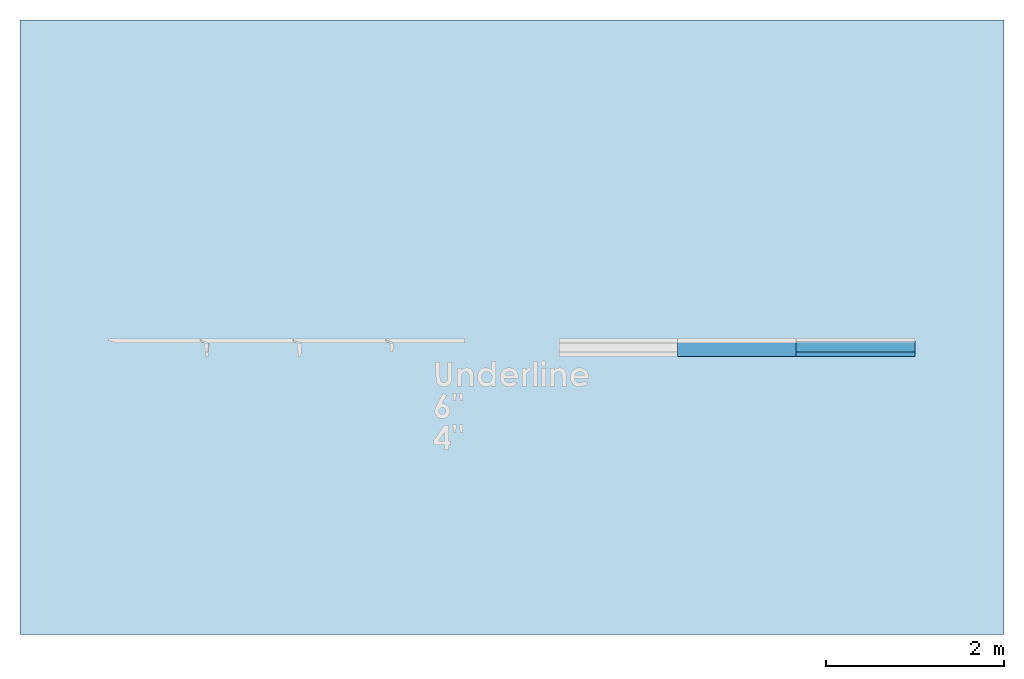
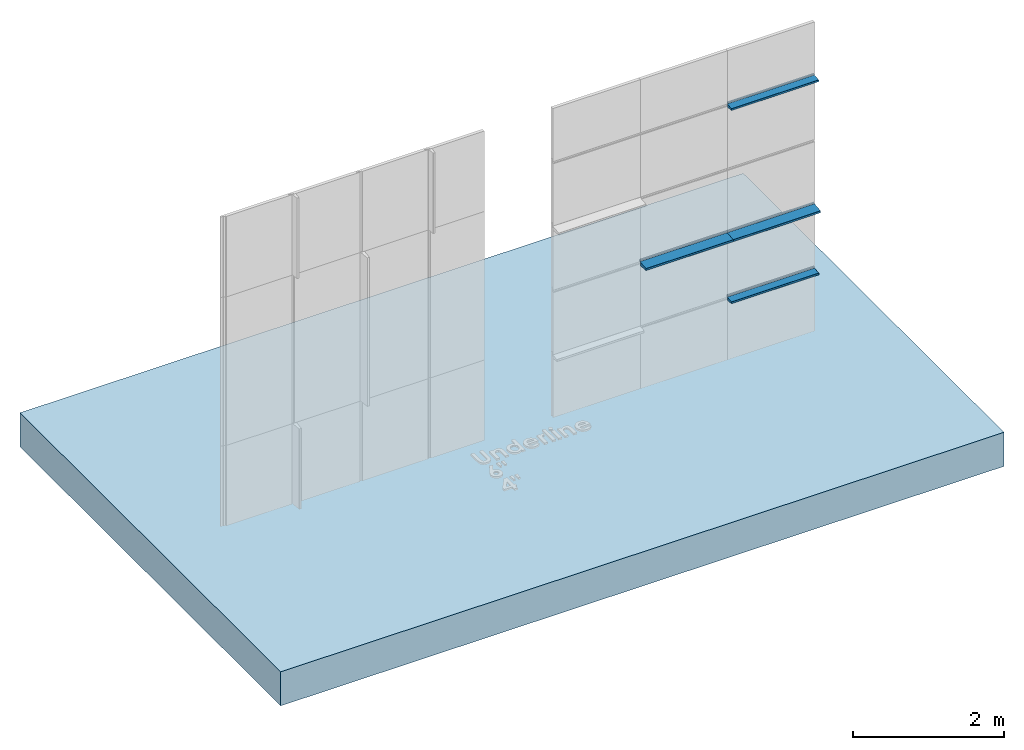
# One storey, part 2 of 6: 4 members, 1 slab, 1 element without a shape of its own.
"""IFC2X3 building model written with IfcOpenShell, lengths in millimetres."""

from ifc_helpers import new_model, entity, si_unit, converted_unit, derived_unit, direction, frame, frame_2d, origin, place, context, subcontext, project, spatial, polyline, circle_curve, parameter, trimmed, segment, composite_curve, rectangle, outline, extrude, source, transform, mapped, material, layer, layer_set, layer_usage, type_object, type_shapes, element, aggregate, save


model = new_model("IFC2X3")

# Units and contexts
model_context = context("Model", 3, precision=0.01, world=origin(), true_north=direction((6.123031769111886e-17, 1.0)))
body_context = subcontext(model_context, "Body", "Model", "MODEL_VIEW")
ifc_project = project(units=[si_unit("LENGTHUNIT", "METRE", prefix="MILLI"), si_unit("AREAUNIT", "SQUARE_METRE"), si_unit("VOLUMEUNIT", "CUBIC_METRE"), converted_unit("PLANEANGLEUNIT", "DEGREE", entity("IfcPlaneAngleMeasure", 0.017453292519943278), si_unit("PLANEANGLEUNIT", "RADIAN"), dimensions=[0, 0, 0, 0, 0, 0, 0]), si_unit("MASSUNIT", "GRAM", prefix="KILO"), derived_unit("MASSDENSITYUNIT", [(si_unit("MASSUNIT", "GRAM", prefix="KILO"), 1), (si_unit("LENGTHUNIT", "METRE"), -3)]), derived_unit("IONCONCENTRATIONUNIT", [(si_unit("MASSUNIT", "GRAM", prefix="KILO"), 1), (si_unit("LENGTHUNIT", "METRE"), -3)]), derived_unit("MOMENTOFINERTIAUNIT", [(si_unit("LENGTHUNIT", "METRE"), 4)]), si_unit("TIMEUNIT", "SECOND"), si_unit("FREQUENCYUNIT", "HERTZ"), si_unit("THERMODYNAMICTEMPERATUREUNIT", "DEGREE_CELSIUS"), derived_unit("THERMALTRANSMITTANCEUNIT", [(si_unit("MASSUNIT", "GRAM", prefix="KILO"), 1), (si_unit("THERMODYNAMICTEMPERATUREUNIT", "KELVIN"), -1), (si_unit("TIMEUNIT", "SECOND"), -3)]), derived_unit("THERMALCONDUCTANCEUNIT", [(si_unit("MASSUNIT", "GRAM", prefix="KILO"), 1), (si_unit("THERMODYNAMICTEMPERATUREUNIT", "KELVIN"), -1), (si_unit("TIMEUNIT", "SECOND"), -3), (si_unit("LENGTHUNIT", "METRE"), 1)]), derived_unit("VOLUMETRICFLOWRATEUNIT", [(si_unit("LENGTHUNIT", "METRE", prefix="DECI"), 3), (si_unit("TIMEUNIT", "SECOND"), -1)]), derived_unit("MASSFLOWRATEUNIT", [(si_unit("MASSUNIT", "GRAM", prefix="KILO"), 1), (si_unit("TIMEUNIT", "SECOND"), -1)]), derived_unit("ROTATIONALFREQUENCYUNIT", [(si_unit("TIMEUNIT", "SECOND"), -1)]), si_unit("ELECTRICCURRENTUNIT", "AMPERE"), si_unit("ELECTRICVOLTAGEUNIT", "VOLT"), si_unit("POWERUNIT", "WATT"), si_unit("FORCEUNIT", "NEWTON", prefix="KILO"), si_unit("ILLUMINANCEUNIT", "LUX"), si_unit("LUMINOUSFLUXUNIT", "LUMEN"), si_unit("LUMINOUSINTENSITYUNIT", "CANDELA"), si_unit("ENERGYUNIT", "JOULE"), derived_unit("USERDEFINED", [(si_unit("MASSUNIT", "GRAM", prefix="KILO"), -1), (si_unit("LENGTHUNIT", "METRE"), -2), (si_unit("TIMEUNIT", "SECOND"), 3), (si_unit("LUMINOUSFLUXUNIT", "LUMEN"), 1)]), derived_unit("USERDEFINED", [(si_unit("MASSUNIT", "GRAM", prefix="KILO"), 1), (si_unit("TIMEUNIT", "SECOND"), -3), (si_unit("LENGTHUNIT", "METRE"), 3), (si_unit("ELECTRICCURRENTUNIT", "AMPERE"), -2)]), derived_unit("SOUNDPOWERUNIT", [(si_unit("MASSUNIT", "GRAM", prefix="KILO"), 1), (si_unit("TIMEUNIT", "SECOND"), -3), (si_unit("LENGTHUNIT", "METRE"), 2)]), derived_unit("SOUNDPRESSUREUNIT", [(si_unit("MASSUNIT", "GRAM", prefix="KILO"), 1), (si_unit("LENGTHUNIT", "METRE"), -1), (si_unit("TIMEUNIT", "SECOND"), -2)]), derived_unit("LINEARVELOCITYUNIT", [(si_unit("LENGTHUNIT", "METRE"), 1), (si_unit("TIMEUNIT", "SECOND"), -1)]), si_unit("PRESSUREUNIT", "PASCAL"), derived_unit("USERDEFINED", [(si_unit("MASSUNIT", "GRAM", prefix="KILO"), 1), (si_unit("LENGTHUNIT", "METRE"), -2), (si_unit("TIMEUNIT", "SECOND"), -2)]), derived_unit("LINEARFORCEUNIT", [(si_unit("MASSUNIT", "GRAM", prefix="KILO"), 1), (si_unit("TIMEUNIT", "SECOND"), -2)]), derived_unit("PLANARFORCEUNIT", [(si_unit("MASSUNIT", "GRAM", prefix="KILO"), 1), (si_unit("LENGTHUNIT", "METRE"), -1), (si_unit("TIMEUNIT", "SECOND"), -2)]), derived_unit("SPECIFICHEATCAPACITYUNIT", [(si_unit("THERMODYNAMICTEMPERATUREUNIT", "KELVIN"), -1), (si_unit("LENGTHUNIT", "METRE"), 2), (si_unit("TIMEUNIT", "SECOND"), -2)]), derived_unit("HEATFLUXDENSITYUNIT", [(si_unit("MASSUNIT", "GRAM", prefix="KILO"), 1), (si_unit("TIMEUNIT", "SECOND"), -3)]), derived_unit("HEATINGVALUEUNIT", [(si_unit("LENGTHUNIT", "METRE"), 2), (si_unit("TIMEUNIT", "SECOND"), -2)]), derived_unit("VAPORPERMEABILITYUNIT", [(si_unit("LENGTHUNIT", "METRE"), -1), (si_unit("TIMEUNIT", "SECOND"), 1)]), derived_unit("DYNAMICVISCOSITYUNIT", [(si_unit("MASSUNIT", "GRAM", prefix="KILO"), 1), (si_unit("TIMEUNIT", "SECOND"), -1), (si_unit("LENGTHUNIT", "METRE"), -1)]), derived_unit("THERMALEXPANSIONCOEFFICIENTUNIT", [(si_unit("THERMODYNAMICTEMPERATUREUNIT", "KELVIN"), -1)]), derived_unit("MODULUSOFELASTICITYUNIT", [(si_unit("MASSUNIT", "GRAM", prefix="KILO"), 1), (si_unit("LENGTHUNIT", "METRE"), -1), (si_unit("TIMEUNIT", "SECOND"), -2)]), derived_unit("ISOTHERMALMOISTURECAPACITYUNIT", [(si_unit("MASSUNIT", "GRAM", prefix="KILO"), -1), (si_unit("LENGTHUNIT", "METRE"), 3)]), derived_unit("MOISTUREDIFFUSIVITYUNIT", [(si_unit("TIMEUNIT", "SECOND"), -1), (si_unit("LENGTHUNIT", "METRE"), 2)]), derived_unit("MASSPERLENGTHUNIT", [(si_unit("MASSUNIT", "GRAM", prefix="KILO"), 1), (si_unit("LENGTHUNIT", "METRE"), -1)]), derived_unit("THERMALRESISTANCEUNIT", [(si_unit("MASSUNIT", "GRAM", prefix="KILO"), -1), (si_unit("TIMEUNIT", "SECOND"), 3), (si_unit("THERMODYNAMICTEMPERATUREUNIT", "KELVIN"), 1)]), derived_unit("ACCELERATIONUNIT", [(si_unit("LENGTHUNIT", "METRE"), 1), (si_unit("TIMEUNIT", "SECOND"), -2)]), derived_unit("ANGULARVELOCITYUNIT", [(si_unit("TIMEUNIT", "SECOND"), -1), (si_unit("PLANEANGLEUNIT", "RADIAN"), 1)]), derived_unit("LINEARSTIFFNESSUNIT", [(si_unit("MASSUNIT", "GRAM", prefix="KILO"), 1), (si_unit("TIMEUNIT", "SECOND"), -2)]), derived_unit("WARPINGCONSTANTUNIT", [(si_unit("LENGTHUNIT", "METRE"), 6)]), derived_unit("LINEARMOMENTUNIT", [(si_unit("MASSUNIT", "GRAM", prefix="KILO"), 1), (si_unit("LENGTHUNIT", "METRE"), 1), (si_unit("TIMEUNIT", "SECOND"), -2)]), derived_unit("TORQUEUNIT", [(si_unit("MASSUNIT", "GRAM", prefix="KILO"), 1), (si_unit("LENGTHUNIT", "METRE"), 2), (si_unit("TIMEUNIT", "SECOND"), -2)])], contexts=[model_context])

# Site, building, storey
site_placement = place(None, origin())
site = spatial("IfcSite", under=ifc_project, at=site_placement, CompositionType="ELEMENT")
building_placement = place(site_placement, origin())
building = spatial("IfcBuilding", under=site, at=building_placement, Name="de", CompositionType="ELEMENT")
storey_placement = place(building_placement, origin())
storey = spatial("IfcBuildingStorey", under=building, at=storey_placement, CompositionType="ELEMENT", Elevation=0.0)

# Curtain wall, members
curtain_wall_type = type_object("IfcCurtainWallType", Name="Parede cortina:PH_Painel Evolution PIR 50", PredefinedType="NOTDEFINED")
curtain_wall_placement = place(storey_placement, origin())
curtain_wall = element("IfcCurtainWall", 1, at=curtain_wall_placement, inside=storey, type_object=curtain_wall_type, Name="Parede cortina:PH_Painel Evolution PIR 50", ObjectType="Parede cortina:PH_Painel Evolution PIR 50")
ifc_material_1 = material(Name="RAL8000")
member_type_1 = type_object("IfcMemberType", Name="Montante retangular:Horizontal - 4pol - RAL8000", PredefinedType="MULLION", material=ifc_material_1)
shared_shape_1 = source(origin(), body_context, "Body", "SweptSolid", [
    extrude(outline(composite_curve([segment(trimmed(circle_curve(frame_2d((-10.767226450808597, 23.56964714493416), x_axis=(1.0, 0.0)), 2.0), [parameter(180.0000000001234)], [parameter(269.99999999999955)], True, "PARAMETER"), True, "CONTINUOUS"), segment(polyline([(-10.76722645080861, 21.56964714492986), (-4.601685270896741, 21.56964714492986)]), True, "CONTINUOUS"), segment(trimmed(circle_curve(frame_2d((-4.601685270896727, 19.56964714493415), x_axis=(1.0, 0.0)), 2.0), [parameter(4.944074410675592)], [parameter(90.00000000000044)], True, "PARAMETER"), False, "CONTINUOUS"), segment(polyline([(-2.609126680915235, 19.742013804962873), (7.0746737792983225, -92.20271951510317)]), True, "CONTINUOUS"), segment(trimmed(circle_curve(frame_2d((9.067232369279779, -92.03035285506587), x_axis=(1.0, 0.0)), 2.0), [parameter(184.94407441092025)], [parameter(269.99999999999943)], True, "PARAMETER"), True, "CONTINUOUS"), segment(polyline([(9.067232369279765, -94.03035285507015), (35.398314729103575, -94.03035285507015)]), True, "CONTINUOUS"), segment(trimmed(circle_curve(frame_2d((35.39831472910359, -92.0303528550658), x_axis=(1.0, 0.0)), 2.0), [parameter(269.99999999999943)], [parameter(355.0559255890776)], True, "PARAMETER"), True, "CONTINUOUS"), segment(polyline([(37.39087331908506, -92.20271951510317), (45.87771280254755, 5.905144913721081)]), True, "CONTINUOUS"), segment(trimmed(circle_curve(frame_2d((43.88515421256605, 6.0775115737584), x_axis=(1.0, 0.0)), 2.0), [parameter(355.055925589079)], [parameter(90.00000000000034)], True, "PARAMETER"), True, "CONTINUOUS"), segment(polyline([(43.885154212566036, 8.077511573754101), (-0.5963520951609951, 8.077511573753931)]), True, "CONTINUOUS"), segment(polyline([(-0.5963520951609951, 8.077511573753931), (-1.6128473859244643, 19.82819713497939)]), True, "CONTINUOUS"), segment(trimmed(circle_curve(frame_2d((-4.601685270896727, 19.56964714493415), x_axis=(1.0, 0.0)), 3.0), [parameter(4.944074410715998)], [parameter(90.00000000000009)], True, "PARAMETER"), True, "CONTINUOUS"), segment(polyline([(-4.601685270896748, 22.56964714492983), (-10.767226450808607, 22.56964714492983)]), True, "CONTINUOUS"), segment(trimmed(circle_curve(frame_2d((-10.767226450808597, 23.56964714493416), x_axis=(1.0, 0.0)), 1.0), [parameter(180.000000000247)], [parameter(269.9999999999999)], True, "PARAMETER"), False, "CONTINUOUS"), segment(polyline([(-11.76722645080864, 23.569647144929842), (-11.76722645080864, 27.56964714492988)]), True, "CONTINUOUS"), segment(trimmed(circle_curve(frame_2d((-14.767226450808636, 27.569647144934162), x_axis=(1.0, 0.0)), 3.0), [parameter(359.9999999999176)], [parameter(90.00000000000009)], True, "PARAMETER"), True, "CONTINUOUS"), segment(polyline([(-14.767226450808653, 30.569647144929842), (-32.26722645080865, 30.569647144929842)]), True, "CONTINUOUS"), segment(polyline([(-32.26722645080865, 30.569647144929842), (-32.26722645080865, 29.56964714492985)]), True, "CONTINUOUS"), segment(polyline([(-32.26722645080865, 29.56964714492985), (-14.767226450808646, 29.56964714492985)]), True, "CONTINUOUS"), segment(trimmed(circle_curve(frame_2d((-14.767226450808636, 27.569647144934162), x_axis=(1.0, 0.0)), 2.0), [parameter(359.99999999987733)], [parameter(90.00000000000044)], True, "PARAMETER"), False, "CONTINUOUS"), segment(polyline([(-12.767226450808614, 27.56964714492988), (-12.767226450808614, 23.569647144929842)]), True, "CONTINUOUS")], self_intersect=False)), frame((-32.26722645080865, 34.704034320940295, -1333.3333333333333), z_axis=(0.0, 0.0, 1.0), x_axis=(-1.0, 0.0, 0.0)), (0.0, 0.0, 1.0), 1333.3333333333335),
])
type_shapes(member_type_1, [shared_shape_1])
member_1_placement = place(curtain_wall_placement, frame((4321.334477308138, 792.6007792258406, 4160.0), z_axis=(1.0, 0.0, 0.0), x_axis=(0.0, 0.0, 1.0)))
member_1 = element("IfcMember", 2, at=member_1_placement, type_object=member_type_1, material=ifc_material_1, Name="Montante retangular:Horizontal - 4pol - RAL8000", ObjectType="Montante retangular:Horizontal - 4pol - RAL8000", context=body_context, shape_type="MappedRepresentation", body=[
    mapped(shared_shape_1, transform((0.0, 0.0, 0.0), scale=1.0)),
])
member_2_placement = place(curtain_wall_placement, frame((4321.334477308138, 792.6007792258406, 1040.0), z_axis=(1.0, 0.0, 0.0), x_axis=(0.0, 0.0, 1.0)))
member_2 = element("IfcMember", 3, at=member_2_placement, type_object=member_type_1, material=ifc_material_1, Name="Montante retangular:Horizontal - 4pol - RAL8000", ObjectType="Montante retangular:Horizontal - 4pol - RAL8000", context=body_context, shape_type="MappedRepresentation", body=[
    mapped(shared_shape_1, transform((0.0, 0.0, 0.0), scale=1.0)),
])
ifc_material_2 = material(Name="RAL5010")
member_type_2 = type_object("IfcMemberType", Name="Montante retangular:Horizontal - 6pol - RAL5010", PredefinedType="MULLION", material=ifc_material_2)
shared_shape_2 = source(origin(), body_context, "Body", "SweptSolid", [
    extrude(outline(composite_curve([segment(trimmed(circle_curve(frame_2d((-12.708419144261761, 32.99351776582026), x_axis=(1.0, 0.0)), 2.0), [parameter(180.00000000012372)], [parameter(269.99999999999955)], True, "PARAMETER"), True, "CONTINUOUS"), segment(polyline([(-12.708419144261772, 30.993517765815945), (-6.5428779643499055, 30.993517765815945)]), True, "CONTINUOUS"), segment(trimmed(circle_curve(frame_2d((-6.542877964349891, 28.99351776582025), x_axis=(1.0, 0.0)), 2.0), [parameter(4.944074410675286)], [parameter(90.00000000000044)], True, "PARAMETER"), False, "CONTINUOUS"), segment(polyline([(-4.550319374368399, 29.16588442584896), (9.442647586670304, -132.59281364375465)]), True, "CONTINUOUS"), segment(trimmed(circle_curve(frame_2d((11.435206176651803, -132.42044698371728), x_axis=(1.0, 0.0)), 2.0), [parameter(184.94407441092028)], [parameter(269.99999999999943)], True, "PARAMETER"), True, "CONTINUOUS"), segment(polyline([(11.435206176651782, -134.42044698372152), (39.15037158145834, -134.42044698372152)]), True, "CONTINUOUS"), segment(trimmed(circle_curve(frame_2d((39.15037158145834, -132.42044698371723), x_axis=(1.0, 0.0)), 2.0), [parameter(269.99999999999943)], [parameter(355.0559255890777)], True, "PARAMETER"), True, "CONTINUOUS"), segment(polyline([(41.14293017143985, -132.5928136437546), (53.89191955946509, 14.785503681813655)]), True, "CONTINUOUS"), segment(trimmed(circle_curve(frame_2d((51.866664103826615, 14.960698790437228), x_axis=(1.0, 0.0)), 2.0328189753830666), [parameter(355.0559255890807)], [parameter(89.99999999999963)], True, "PARAMETER"), True, "CONTINUOUS"), segment(polyline([(51.866664103826615, 16.99351776581598), (-2.4936118795463216, 16.993517765815813)]), True, "CONTINUOUS"), segment(polyline([(-2.4936118795463145, 16.993517765815813), (-3.633089964324295, 30.165884425848937)]), True, "CONTINUOUS"), segment(trimmed(circle_curve(frame_2d((-5.625648554305755, 29.993517765820243), x_axis=(1.0, 0.0)), 2.0), [parameter(4.944074410674829)], [parameter(90.00000000000009)], True, "PARAMETER"), True, "CONTINUOUS"), segment(polyline([(-5.625648554305766, 31.993517765815955), (-11.708419144261796, 31.993517765815955)]), True, "CONTINUOUS"), segment(trimmed(circle_curve(frame_2d((-11.708419144261786, 33.99351776582025), x_axis=(1.0, 0.0)), 2.0), [parameter(180.00000000012324)], [parameter(269.9999999999999)], True, "PARAMETER"), False, "CONTINUOUS"), segment(polyline([(-13.708419144261804, 33.99351776581594), (-13.708419144261804, 37.993517765815945)]), True, "CONTINUOUS"), segment(trimmed(circle_curve(frame_2d((-15.708419144261821, 37.99351776582025), x_axis=(1.0, 0.0)), 2.0), [parameter(359.9999999998766)], [parameter(90.00000000000009)], True, "PARAMETER"), True, "CONTINUOUS"), segment(polyline([(-15.708419144261835, 39.993517765815966), (-35.208419144261754, 39.993517765815966)]), True, "CONTINUOUS"), segment(polyline([(-35.208419144261754, 39.993517765815966), (-35.208419144261754, 38.99351776581595)]), True, "CONTINUOUS"), segment(polyline([(-35.208419144261754, 38.99351776581595), (-16.70841914426181, 38.99351776581595)]), True, "CONTINUOUS"), segment(trimmed(circle_curve(frame_2d((-16.7084191442618, 36.99351776582026), x_axis=(1.0, 0.0)), 2.0), [parameter(359.99999999987705)], [parameter(90.00000000000044)], True, "PARAMETER"), False, "CONTINUOUS"), segment(polyline([(-14.708419144261779, 36.993517765815966), (-14.708419144261779, 32.99351776581593)]), True, "CONTINUOUS")], self_intersect=False)), frame((-35.20841914426175, 43.98809022500597, -1333.3333333333335), z_axis=(0.0, 0.0, 1.0), x_axis=(-1.0, 0.0, 0.0)), (0.0, 0.0, 1.0), 1333.3333333333333),
])
type_shapes(member_type_2, [shared_shape_2])
member_3_placement = place(curtain_wall_placement, frame((2988.0011439748046, 792.6007792258439, 2080.0), z_axis=(1.0, 0.0, 0.0), x_axis=(0.0, 0.0, 1.0)))
member_3 = element("IfcMember", 4, at=member_3_placement, type_object=member_type_2, material=ifc_material_2, Name="Montante retangular:Horizontal - 6pol - RAL5010", ObjectType="Montante retangular:Horizontal - 6pol - RAL5010", context=body_context, shape_type="MappedRepresentation", body=[
    mapped(shared_shape_2, transform((0.0, 0.0, 0.0), scale=1.0)),
])
member_type_3 = type_object("IfcMemberType", Name="Montante retangular:Horizontal - 6pol - RAL5010", PredefinedType="MULLION", material=ifc_material_2)
shared_shape_3 = source(origin(), body_context, "Body", "SweptSolid", [
    extrude(outline(composite_curve([segment(trimmed(circle_curve(frame_2d((-12.708419144261761, 32.99351776582026), x_axis=(1.0, 0.0)), 2.0), [parameter(180.00000000012372)], [parameter(269.99999999999955)], True, "PARAMETER"), True, "CONTINUOUS"), segment(polyline([(-12.708419144261772, 30.993517765815945), (-6.5428779643499055, 30.993517765815945)]), True, "CONTINUOUS"), segment(trimmed(circle_curve(frame_2d((-6.542877964349891, 28.99351776582025), x_axis=(1.0, 0.0)), 2.0), [parameter(4.944074410675286)], [parameter(90.00000000000044)], True, "PARAMETER"), False, "CONTINUOUS"), segment(polyline([(-4.550319374368399, 29.16588442584896), (9.442647586670304, -132.59281364375465)]), True, "CONTINUOUS"), segment(trimmed(circle_curve(frame_2d((11.435206176651803, -132.42044698371728), x_axis=(1.0, 0.0)), 2.0), [parameter(184.94407441092028)], [parameter(269.99999999999943)], True, "PARAMETER"), True, "CONTINUOUS"), segment(polyline([(11.435206176651782, -134.42044698372152), (39.15037158145834, -134.42044698372152)]), True, "CONTINUOUS"), segment(trimmed(circle_curve(frame_2d((39.15037158145834, -132.42044698371723), x_axis=(1.0, 0.0)), 2.0), [parameter(269.99999999999943)], [parameter(355.0559255890777)], True, "PARAMETER"), True, "CONTINUOUS"), segment(polyline([(41.14293017143985, -132.5928136437546), (53.89191955946509, 14.785503681813655)]), True, "CONTINUOUS"), segment(trimmed(circle_curve(frame_2d((51.866664103826615, 14.960698790437228), x_axis=(1.0, 0.0)), 2.0328189753830666), [parameter(355.0559255890807)], [parameter(89.99999999999963)], True, "PARAMETER"), True, "CONTINUOUS"), segment(polyline([(51.866664103826615, 16.99351776581598), (-2.4936118795463216, 16.993517765815813)]), True, "CONTINUOUS"), segment(polyline([(-2.4936118795463145, 16.993517765815813), (-3.633089964324295, 30.165884425848937)]), True, "CONTINUOUS"), segment(trimmed(circle_curve(frame_2d((-5.625648554305755, 29.993517765820243), x_axis=(1.0, 0.0)), 2.0), [parameter(4.944074410674829)], [parameter(90.00000000000009)], True, "PARAMETER"), True, "CONTINUOUS"), segment(polyline([(-5.625648554305766, 31.993517765815955), (-11.708419144261796, 31.993517765815955)]), True, "CONTINUOUS"), segment(trimmed(circle_curve(frame_2d((-11.708419144261786, 33.99351776582025), x_axis=(1.0, 0.0)), 2.0), [parameter(180.00000000012324)], [parameter(269.9999999999999)], True, "PARAMETER"), False, "CONTINUOUS"), segment(polyline([(-13.708419144261804, 33.99351776581594), (-13.708419144261804, 37.993517765815945)]), True, "CONTINUOUS"), segment(trimmed(circle_curve(frame_2d((-15.708419144261821, 37.99351776582025), x_axis=(1.0, 0.0)), 2.0), [parameter(359.9999999998766)], [parameter(90.00000000000009)], True, "PARAMETER"), True, "CONTINUOUS"), segment(polyline([(-15.708419144261835, 39.993517765815966), (-35.208419144261754, 39.993517765815966)]), True, "CONTINUOUS"), segment(polyline([(-35.208419144261754, 39.993517765815966), (-35.208419144261754, 38.99351776581595)]), True, "CONTINUOUS"), segment(polyline([(-35.208419144261754, 38.99351776581595), (-16.70841914426181, 38.99351776581595)]), True, "CONTINUOUS"), segment(trimmed(circle_curve(frame_2d((-16.7084191442618, 36.99351776582026), x_axis=(1.0, 0.0)), 2.0), [parameter(359.99999999987705)], [parameter(90.00000000000044)], True, "PARAMETER"), False, "CONTINUOUS"), segment(polyline([(-14.708419144261779, 36.993517765815966), (-14.708419144261779, 32.99351776581593)]), True, "CONTINUOUS")], self_intersect=False)), frame((-35.20841914426175, 43.98809022500597, -1333.3333333333333), z_axis=(0.0, 0.0, 1.0), x_axis=(-1.0, 0.0, 0.0)), (0.0, 0.0, 1.0), 1333.3333333333335),
])
type_shapes(member_type_3, [shared_shape_3])
member_4_placement = place(curtain_wall_placement, frame((4321.334477308138, 792.6007792258406, 2080.0), z_axis=(1.0, 0.0, 0.0), x_axis=(0.0, 0.0, 1.0)))
member_4 = element("IfcMember", 5, at=member_4_placement, type_object=member_type_3, material=ifc_material_2, Name="Montante retangular:Horizontal - 6pol - RAL5010", ObjectType="Montante retangular:Horizontal - 6pol - RAL5010", context=body_context, shape_type="MappedRepresentation", body=[
    mapped(shared_shape_3, transform((0.0, 0.0, 0.0), scale=1.0)),
])
aggregate(curtain_wall, [member_3, member_1, member_4, member_2])

# Slab
ifc_material_3 = material(Name="Piso de concreto")
ifc_layer_1 = layer(ifc_material_3, 20.0)
ifc_material_4 = material(Name=".Concreto - Contrapiso")
ifc_layer_2 = layer(ifc_material_4, 30.0)
ifc_material_5 = material(Name="Concreto - e")
ifc_layer_3 = layer(ifc_material_5, 500.00000000000006)
ifc_layer_set = layer_set([ifc_layer_1, ifc_layer_2, ifc_layer_3], Name="Piso:Concreto + Piso")
ifc_layer_usage = layer_usage(ifc_layer_set, "AXIS3", "POSITIVE", 0.0)
slab_type = type_object("IfcSlabType", Name="Piso:Concreto + Piso", PredefinedType="FLOOR", material=ifc_layer_set)
slab_placement = place(storey_placement, origin())
element("IfcSlab", 6, at=slab_placement, inside=storey, type_object=slab_type, material=ifc_layer_usage, Name="Piso:Concreto + Piso", ObjectType="Piso:Concreto + Piso", PredefinedType="FLOOR", context=body_context, shape_type="SweptSolid", body=[
    extrude(rectangle(XDim=6900.851428571619, YDim=11051.385511815788, at=frame_2d((-2.2737367544323206e-13, 0.0), x_axis=(1.0, 0.0))), frame((-204.35827859975265, 943.8970806008577, 0.0), z_axis=(0.0, 0.0, -1.0), x_axis=(0.0, 1.0, 0.0)), (0.0, 0.0, 1.0), 550.0),
])

save(model, "model.ifc")
